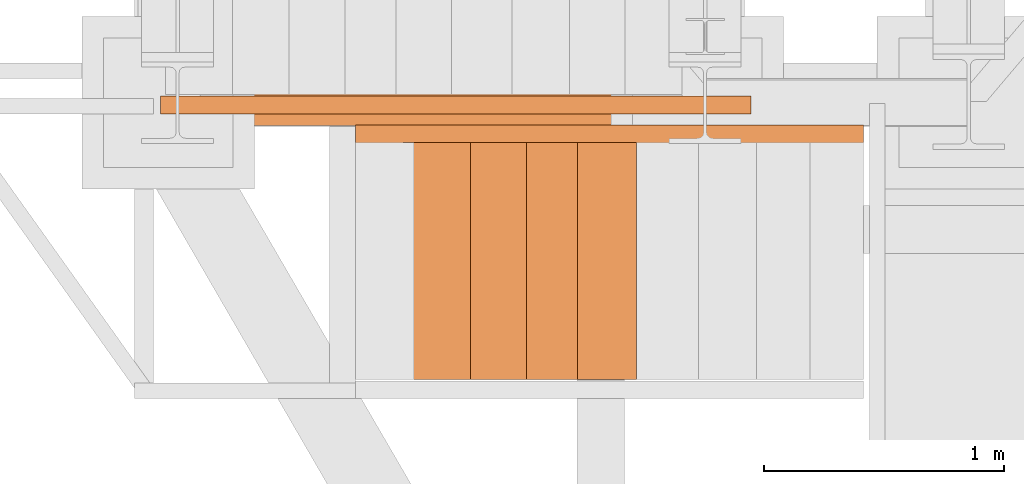
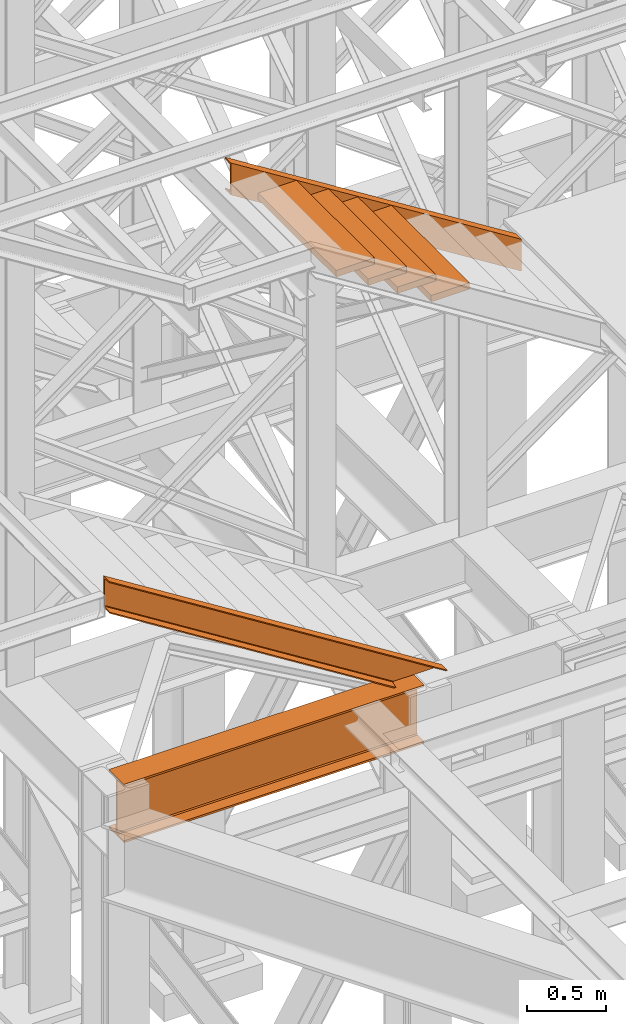
# One storey, part 21 of 208: 7 proxies.
"""IFC2X3 building model written with IfcOpenShell, lengths in millimetres."""

import ifcopenshell
import ifcopenshell.guid

model = None  # the IFC model being written
_history = None  # IfcOwnerHistory: only IFC2X3 demands one
_inside = {}  # id of a spatial element -> (the spatial element, [elements in it])
_under = {}  # id of a project, library or spatial element -> (it, [spatial elements below it])
_declared = {}  # id of a project -> (the project, [libraries it declares])
_typed = {}  # id of a type object -> (the type object, [elements of that type])
_made_of = {}  # id of a material, layer set ... -> (it, [elements and type objects made of it])


def new_model(schema):
    """Start an empty IFC model of exactly this schema.

    Asked for "IFC4X3", IfcOpenShell would pick the latest addendum, in which some entities
    have other attributes; the version numbers below select the first issue.
    IFC2X3 requires an IfcOwnerHistory on every rooted entity: one is made here for all.
    """
    global model, _history
    if schema == "IFC4X3":
        model = ifcopenshell.file(schema_version=(4, 3, 0, 0))
    else:
        model = ifcopenshell.file(schema=schema)
    _inside.clear()
    _under.clear()
    _declared.clear()
    _typed.clear()
    _made_of.clear()
    _history = None
    if model.schema == "IFC2X3":
        org = make("IfcOrganization", Name="unknown")
        user = make(
            "IfcPersonAndOrganization",
            ThePerson=make("IfcPerson", FamilyName="unknown"),
            TheOrganization=org,
        )
        app = make(
            "IfcApplication",
            ApplicationDeveloper=org,
            Version="unknown",
            ApplicationFullName="unknown",
            ApplicationIdentifier="unknown",
        )
        _history = make(
            "IfcOwnerHistory",
            OwningUser=user,
            OwningApplication=app,
            ChangeAction="ADDED",
            CreationDate=0,
        )
    return model


def make(cls, **values):
    """One entity of the class cls with the attributes given. An attribute that is None is left unset."""
    return model.create_entity(
        cls, **{name: value for name, value in values.items() if value is not None}
    )


def entity(cls, *values):
    """Any entity or typed value of the class cls, its attributes in the order of the schema. None: left unset."""
    e = model.create_entity(cls)
    for i, value in enumerate(values):
        if value is not None:
            e[i] = value
    return e


def rooted(cls, **values):
    """An entity with a GlobalId (a new one), such as an element, a storey or a relation."""
    return make(cls, GlobalId=ifcopenshell.guid.new(), OwnerHistory=_history, **values)


def si_unit(unit_type, name, prefix=None):
    """IfcSIUnit, for example si_unit("LENGTHUNIT", "METRE", prefix="MILLI")."""
    return make("IfcSIUnit", UnitType=unit_type, Prefix=prefix, Name=name)


def converted_unit(unit_type, name, factor, base, dimensions=None, offset=None):
    """IfcConversionBasedUnit, such as the inch: factor (a typed value) times the base unit."""
    return make(
        "IfcConversionBasedUnit"
        if offset is None
        else "IfcConversionBasedUnitWithOffset",
        ConversionOffset=offset,
        Dimensions=None
        if dimensions is None
        else entity("IfcDimensionalExponents", *dimensions),
        UnitType=unit_type,
        Name=name,
        ConversionFactor=make(
            "IfcMeasureWithUnit", ValueComponent=factor, UnitComponent=base
        ),
    )


def assignment(units):
    """IfcUnitAssignment: the units of a project."""
    return None if units is None else make("IfcUnitAssignment", Units=units)


def point(xyz):
    """IfcCartesianPoint."""
    return None if xyz is None else make("IfcCartesianPoint", Coordinates=xyz)


def direction(xyz):
    """IfcDirection."""
    return None if xyz is None else make("IfcDirection", DirectionRatios=xyz)


def frame(location, z_axis=None, x_axis=None):
    """IfcAxis2Placement3D, a coordinate frame: its origin and axes. An axis left out is left unset."""
    return make(
        "IfcAxis2Placement3D",
        Location=point(location),
        Axis=direction(z_axis),
        RefDirection=direction(x_axis),
    )


def origin():
    """The frame at (0, 0, 0) with its axes left unset."""
    return frame((0.0, 0.0, 0.0))


def origin_with_axes():
    """The frame at (0, 0, 0) with the z axis (0, 0, 1) and the x axis (1, 0, 0) written out."""
    return frame((0.0, 0.0, 0.0), z_axis=(0.0, 0.0, 1.0), x_axis=(1.0, 0.0, 0.0))


def place(relative_to, where):
    """IfcLocalPlacement: puts the frame where relative to a parent placement (None: the world)."""
    return make(
        "IfcLocalPlacement", PlacementRelTo=relative_to, RelativePlacement=where
    )


def context(
    kind, dimensions, precision=None, world=None, true_north=None, identifier=None
):
    """IfcGeometricRepresentationContext, for example the 3D "Model" context."""
    return make(
        "IfcGeometricRepresentationContext",
        ContextIdentifier=identifier,
        ContextType=kind,
        CoordinateSpaceDimension=dimensions,
        Precision=precision,
        WorldCoordinateSystem=world,
        TrueNorth=true_north,
    )


def subcontext(parent, identifier, kind, view, scale=None):
    """IfcGeometricRepresentationSubContext, for example "Body" below "Model"."""
    return make(
        "IfcGeometricRepresentationSubContext",
        ContextIdentifier=identifier,
        ContextType=kind,
        ParentContext=parent,
        TargetScale=scale,
        TargetView=view,
    )


def project(units=None, contexts=None):
    """IfcProject with its units and contexts."""
    return rooted(
        "IfcProject",
        Name="project",
        RepresentationContexts=contexts,
        UnitsInContext=assignment(units),
    )


def spatial(cls, under=None, at=None, **own):
    """A site, building, storey or space (cls), placed at a placement, below another one or the project."""
    s = rooted(cls, ObjectPlacement=at, **own)
    if under is not None:
        _under.setdefault(under.id(), (under, []))[1].append(s)
    return s


def faces_of(points, faces, orient=None, outer=None):
    """IfcFace entities. A face is a list of loops; a loop is a list of indices into points, from 0.

    orient and outer hold one flag for each loop. By default every Orientation is true, the
    first loop of a face is its IfcFaceOuterBound and the others are IfcFaceBound.
    """
    made = []
    for i, loops in enumerate(faces):
        bounds = []
        for j, loop in enumerate(loops):
            is_outer = j == 0 if outer is None else outer[i][j]
            bounds.append(
                make(
                    "IfcFaceOuterBound" if is_outer else "IfcFaceBound",
                    Bound=make("IfcPolyLoop", Polygon=[points[k] for k in loop]),
                    Orientation=True if orient is None else orient[i][j],
                )
            )
        made.append(make("IfcFace", Bounds=bounds))
    return made


def faceted_brep(points, faces, orient=None, outer=None, voids=None):
    """IfcFacetedBrep: a solid bounded by flat faces; with voids (closed shells), ...WithVoids."""
    shared = [point(p) for p in points]
    hull = make("IfcClosedShell", CfsFaces=faces_of(shared, faces, orient, outer))
    if voids is None:
        return make("IfcFacetedBrep", Outer=hull)
    return make(
        "IfcFacetedBrepWithVoids",
        Outer=hull,
        Voids=[
            make(cls, CfsFaces=faces_of(shared, fs, o, b)) for cls, fs, o, b in voids
        ],
    )


def shape(context_of_items, identifier, shape_type, items):
    """IfcShapeRepresentation: the items that make up one representation, for example the "Body"."""
    return make(
        "IfcShapeRepresentation",
        ContextOfItems=context_of_items,
        RepresentationIdentifier=identifier,
        RepresentationType=shape_type,
        Items=items,
    )


def made_of(thing, what):
    """Note that an element or type object is made of a material, layer set ...; save() writes the relation."""
    if what is not None:
        _made_of.setdefault(what.id(), (what, []))[1].append(thing)
    return thing


def element(
    cls,
    number,
    at=None,
    inside=None,
    cuts=None,
    type_object=None,
    material=None,
    context=None,
    identifier="Body",
    shape_type=None,
    held_by="IfcProductDefinitionShape",
    body=None,
    shapes=None,
    **own,
):
    """One element of the class cls, such as IfcWall. Its Tag is "e" and its number.

    at: its placement. inside: the storey or other place that contains it. cuts: it is an
    opening in that element (IfcRelVoidsElement). A single representation is given by context,
    identifier, shape_type and body (its items); several are given by shapes. held_by: the class
    of the entity that holds the representations. save() writes the other relations.
    """
    e = rooted(cls, Tag="e%d" % number, ObjectPlacement=at, **own)
    if body is not None:
        shapes = [shape(context, identifier, shape_type, body)]
    if shapes is not None:
        e.Representation = make(held_by, Representations=shapes)
    if inside is not None:
        _inside.setdefault(inside.id(), (inside, []))[1].append(e)
    if cuts is not None:
        rooted(
            "IfcRelVoidsElement", RelatingBuildingElement=cuts, RelatedOpeningElement=e
        )
    if type_object is not None:
        _typed.setdefault(type_object.id(), (type_object, []))[1].append(e)
    return made_of(e, material)


def aggregate(whole, parts):
    """IfcRelAggregates: a whole, such as a stair, and the parts it consists of."""
    return rooted("IfcRelAggregates", RelatingObject=whole, RelatedObjects=parts)


def save(model, path):
    """Write the relations noted so far, then the file.

    IfcRelAggregates (storeys below a building ...), IfcRelContainedInSpatialStructure (elements
    in a storey), IfcRelDefinesByType, IfcRelAssociatesMaterial and IfcRelDeclares: one each for
    every whole, place, type object, material and project.
    """
    for whole, parts in _under.values():
        aggregate(whole, parts)
    for where, things in _inside.values():
        rooted(
            "IfcRelContainedInSpatialStructure",
            RelatedElements=things,
            RelatingStructure=where,
        )
    for kind, things in _typed.values():
        rooted("IfcRelDefinesByType", RelatedObjects=things, RelatingType=kind)
    for what, things in _made_of.values():
        rooted("IfcRelAssociatesMaterial", RelatedObjects=things, RelatingMaterial=what)
    for by, libraries in _declared.values():
        rooted("IfcRelDeclares", RelatingContext=by, RelatedDefinitions=libraries)
    model.write(path)


model = new_model("IFC2X3")

# Units and contexts
model_context = context("Model", 3, precision=1e-05, world=origin())
plan_context = context("Plan", 3, precision=1e-05, world=origin())
body_context = subcontext(model_context, "Body", "Model", "MODEL_VIEW")
ifc_project = project(units=[si_unit("LENGTHUNIT", "METRE", prefix="MILLI"), converted_unit("PLANEANGLEUNIT", "DEGREE", entity("IfcPlaneAngleMeasure", 0.0174532925199433), si_unit("PLANEANGLEUNIT", "RADIAN"), dimensions=[0, 0, 0, 0, 0, 0, 0]), si_unit("AREAUNIT", "SQUARE_METRE"), si_unit("VOLUMEUNIT", "CUBIC_METRE")], contexts=[model_context, plan_context])

# Building, storey
building_placement = place(None, origin())
building = spatial("IfcBuilding", under=ifc_project, at=building_placement, CompositionType="COMPLEX")
storey_placement = place(building_placement, origin_with_axes())
storey = spatial("IfcBuildingStorey", under=building, at=storey_placement, Name="Geschoss", CompositionType="ELEMENT")

# Proxies
proxy_1_placement = place(storey_placement, frame((-3300.745031419179, -17357.574399786, 4834.989987483023), z_axis=(0.0, 0.0, 1.0), x_axis=(1.0, 0.0, 0.0)))
element("IfcBuildingElementProxy", 1, at=proxy_1_placement, inside=storey, context=body_context, shape_type="Brep", body=[
    faceted_brep([(2188.009999895692, 0.00999999999839929, 450.0100178813937), (2188.009999895692, 190.0100125169738, 450.0100178813937), (2188.009999895692, 190.0100125169738, 435.4100240564349), (2188.009999895692, 120.7100073045476, 435.4100091552737), (2188.009999895692, 109.8415622657522, 433.2347078418734), (2188.009999895692, 101.8853126263603, 425.2784563398363), (2188.009999895692, 99.71000619068582, 414.4100113010409), (2188.009999895692, 99.71000619068582, 35.60999167919181), (2188.009999895692, 101.8853126263603, 24.74154664039634), (2188.009999895692, 109.8415622657522, 16.78529513835929), (2188.009999895692, 120.7100073045476, 14.60999382495902), (2188.009999895692, 190.0100125169738, 14.60999382495902), (2188.009999895692, 190.0100125169738, 0.01000000000021828), (2188.009999895692, 0.00999999999839929, 0.01000000000021828), (2188.009999895692, 0.00999999999839929, 14.60999382495902), (2188.009999895692, 69.31000521242458, 14.60999382495902), (2188.009999895692, 80.17845025122006, 16.78529513835929), (2188.009999895692, 88.13469989061196, 24.74154664039634), (2188.009999895692, 90.31000632628638, 35.60999167919181), (2188.009999895692, 90.31000632628638, 414.4100113010409), (2188.009999895692, 88.13469989061196, 425.2784563398363), (2188.009999895692, 80.17845025122006, 433.2347078418734), (2188.009999895692, 69.31000521242458, 435.4100091552737), (2188.009999895692, 0.00999999999839929, 435.4100240564349), (2188.009999895692, 190.0100125169738, 450.0100178813937), (2188.009999895692, 0.00999999999839929, 450.0100178813937), (0.01000000000021828, 0.00999999999839929, 450.0100178813937), (0.01000000000021828, 190.0100125169738, 450.0100178813937), (2188.009999895692, 190.0100125169738, 435.4100240564349), (2188.009999895692, 190.0100125169738, 450.0100178813937), (0.01000000000021828, 190.0100125169738, 450.0100178813937), (0.01000000000021828, 190.0100125169738, 435.4100240564349), (2188.009999895692, 120.7100073045476, 435.4100091552737), (2188.009999895692, 190.0100125169738, 435.4100240564349), (0.01000000000021828, 190.0100125169738, 435.4100240564349), (0.01000000000021828, 120.7100073045476, 435.4100091552737), (2188.009999895692, 109.8415622657522, 433.2347078418734), (2188.009999895692, 120.7100073045476, 435.4100091552737), (0.01000000000021828, 120.7100073045476, 435.4100091552737), (0.01000000000021828, 109.8415622657522, 433.2347078418734), (2188.009999895692, 101.8853126263603, 425.2784563398363), (2188.009999895692, 109.8415622657522, 433.2347078418734), (0.01000000000021828, 109.8415622657522, 433.2347078418734), (0.01000000000021828, 101.8853126263603, 425.2784563398363), (2188.009999895692, 99.71000619068582, 414.4100113010409), (2188.009999895692, 101.8853126263603, 425.2784563398363), (0.01000000000021828, 101.8853126263603, 425.2784563398363), (0.01000000000021828, 99.71000619068582, 414.4100113010409), (2188.009999895692, 99.71000619068582, 35.60999167919181), (2188.009999895692, 99.71000619068582, 414.4100113010409), (0.01000000000021828, 99.71000619068582, 414.4100113010409), (0.01000000000021828, 99.71000619068582, 35.60999167919181), (2188.009999895692, 101.8853126263603, 24.74154664039634), (2188.009999895692, 99.71000619068582, 35.60999167919181), (0.01000000000021828, 99.71000619068582, 35.60999167919181), (0.01000000000021828, 101.8853126263603, 24.74154664039634), (2188.009999895692, 109.8415622657522, 16.78529513835929), (2188.009999895692, 101.8853126263603, 24.74154664039634), (0.01000000000021828, 101.8853126263603, 24.74154664039634), (0.01000000000021828, 109.8415622657522, 16.78529513835929), (2188.009999895692, 120.7100073045476, 14.60999382495902), (2188.009999895692, 109.8415622657522, 16.78529513835929), (0.01000000000021828, 109.8415622657522, 16.78529513835929), (0.01000000000021828, 120.7100073045476, 14.60999382495902), (2188.009999895692, 190.0100125169738, 14.60999382495902), (2188.009999895692, 120.7100073045476, 14.60999382495902), (0.01000000000021828, 120.7100073045476, 14.60999382495902), (0.01000000000021828, 190.0100125169738, 14.60999382495902), (2188.009999895692, 190.0100125169738, 0.01000000000021828), (2188.009999895692, 190.0100125169738, 14.60999382495902), (0.01000000000021828, 190.0100125169738, 14.60999382495902), (0.01000000000021828, 190.0100125169738, 0.01000000000021828), (2188.009999895692, 0.00999999999839929, 0.01000000000021828), (2188.009999895692, 190.0100125169738, 0.01000000000021828), (0.01000000000021828, 190.0100125169738, 0.01000000000021828), (0.01000000000021828, 0.00999999999839929, 0.01000000000021828), (2188.009999895692, 0.00999999999839929, 14.60999382495902), (2188.009999895692, 0.00999999999839929, 0.01000000000021828), (0.01000000000021828, 0.00999999999839929, 0.01000000000021828), (0.01000000000021828, 0.00999999999839929, 14.60999382495902), (2188.009999895692, 69.31000521242458, 14.60999382495902), (2188.009999895692, 0.00999999999839929, 14.60999382495902), (0.01000000000021828, 0.00999999999839929, 14.60999382495902), (0.01000000000021828, 69.31000521242458, 14.60999382495902), (2188.009999895692, 80.17845025122006, 16.78529513835929), (2188.009999895692, 69.31000521242458, 14.60999382495902), (0.01000000000021828, 69.31000521242458, 14.60999382495902), (0.01000000000021828, 80.17845025122006, 16.78529513835929), (2188.009999895692, 88.13469989061196, 24.74154664039634), (2188.009999895692, 80.17845025122006, 16.78529513835929), (0.01000000000021828, 80.17845025122006, 16.78529513835929), (0.01000000000021828, 88.13469989061196, 24.74154664039634), (2188.009999895692, 90.31000632628638, 35.60999167919181), (2188.009999895692, 88.13469989061196, 24.74154664039634), (0.01000000000021828, 88.13469989061196, 24.74154664039634), (0.01000000000021828, 90.31000632628638, 35.60999167919181), (2188.009999895692, 90.31000632628638, 414.4100113010409), (2188.009999895692, 90.31000632628638, 35.60999167919181), (0.01000000000021828, 90.31000632628638, 35.60999167919181), (0.01000000000021828, 90.31000632628638, 414.4100113010409), (2188.009999895692, 88.13469989061196, 425.2784563398363), (2188.009999895692, 90.31000632628638, 414.4100113010409), (0.01000000000021828, 90.31000632628638, 414.4100113010409), (0.01000000000021828, 88.13469989061196, 425.2784563398363), (2188.009999895692, 80.17845025122006, 433.2347078418734), (2188.009999895692, 88.13469989061196, 425.2784563398363), (0.01000000000021828, 88.13469989061196, 425.2784563398363), (0.01000000000021828, 80.17845025122006, 433.2347078418734), (2188.009999895692, 69.31000521242458, 435.4100091552737), (2188.009999895692, 80.17845025122006, 433.2347078418734), (0.01000000000021828, 80.17845025122006, 433.2347078418734), (0.01000000000021828, 69.31000521242458, 435.4100091552737), (2188.009999895692, 0.00999999999839929, 435.4100240564349), (2188.009999895692, 69.31000521242458, 435.4100091552737), (0.01000000000021828, 69.31000521242458, 435.4100091552737), (0.01000000000021828, 0.00999999999839929, 435.4100240564349), (2188.009999895692, 0.00999999999839929, 450.0100178813937), (2188.009999895692, 0.00999999999839929, 435.4100240564349), (0.01000000000021828, 0.00999999999839929, 435.4100240564349), (0.01000000000021828, 0.00999999999839929, 450.0100178813937), (0.01000000000021828, 0.00999999999839929, 450.0100178813937), (0.01000000000021828, 0.00999999999839929, 435.4100240564349), (0.01000000000021828, 69.31000521242458, 435.4100091552737), (0.01000000000021828, 80.17845025122006, 433.2347078418734), (0.01000000000021828, 88.13469989061196, 425.2784563398363), (0.01000000000021828, 90.31000632628638, 414.4100113010409), (0.01000000000021828, 90.31000632628638, 35.60999167919181), (0.01000000000021828, 88.13469989061196, 24.74154664039634), (0.01000000000021828, 80.17845025122006, 16.78529513835929), (0.01000000000021828, 69.31000521242458, 14.60999382495902), (0.01000000000021828, 0.00999999999839929, 14.60999382495902), (0.01000000000021828, 0.00999999999839929, 0.01000000000021828), (0.01000000000021828, 190.0100125169738, 0.01000000000021828), (0.01000000000021828, 190.0100125169738, 14.60999382495902), (0.01000000000021828, 120.7100073045476, 14.60999382495902), (0.01000000000021828, 109.8415622657522, 16.78529513835929), (0.01000000000021828, 101.8853126263603, 24.74154664039634), (0.01000000000021828, 99.71000619068582, 35.60999167919181), (0.01000000000021828, 99.71000619068582, 414.4100113010409), (0.01000000000021828, 101.8853126263603, 425.2784563398363), (0.01000000000021828, 109.8415622657522, 433.2347078418734), (0.01000000000021828, 120.7100073045476, 435.4100091552737), (0.01000000000021828, 190.0100125169738, 435.4100240564349), (0.01000000000021828, 190.0100125169738, 450.0100178813937)], [[[0, 1, 2, 3, 4, 5, 6, 7, 8, 9, 10, 11, 12, 13, 14, 15, 16, 17, 18, 19, 20, 21, 22, 23]], [[24, 25, 26, 27]], [[28, 29, 30, 31]], [[32, 33, 34, 35]], [[36, 37, 38, 39]], [[40, 41, 42, 43]], [[44, 45, 46, 47]], [[48, 49, 50, 51]], [[52, 53, 54, 55]], [[56, 57, 58, 59]], [[60, 61, 62, 63]], [[64, 65, 66, 67]], [[68, 69, 70, 71]], [[72, 73, 74, 75]], [[76, 77, 78, 79]], [[80, 81, 82, 83]], [[84, 85, 86, 87]], [[88, 89, 90, 91]], [[92, 93, 94, 95]], [[96, 97, 98, 99]], [[100, 101, 102, 103]], [[104, 105, 106, 107]], [[108, 109, 110, 111]], [[112, 113, 114, 115]], [[116, 117, 118, 119]], [[120, 121, 122, 123, 124, 125, 126, 127, 128, 129, 130, 131, 132, 133, 134, 135, 136, 137, 138, 139, 140, 141, 142, 143]]], orient=[[False], [False], [False], [False], [False], [False], [False], [False], [False], [False], [False], [False], [False], [False], [False], [False], [False], [False], [False], [False], [False], [False], [False], [False], [False], [False]]),
])
for number, where, z_axis, x_axis in (
    (2, (-1673.666828882966, -18416.66561009758, 9075.185220743773), (0.0, 0.0, 1.0), (1.0, 0.0, 0.0)),
    (3, (-1919.160184020018, -18416.66561009758, 9225.654269958271), (0.0, 0.0, 1.0), (1.0, 0.0, 0.0)),
):
    element("IfcBuildingElementProxy", number, at=place(storey_placement, frame(where, z_axis=z_axis, x_axis=x_axis)), inside=storey, context=body_context, shape_type="Brep", body=[
        faceted_brep([(0.009999999999990905, 0.00999999999839929, 0.01000000000021828), (280.2746556316176, 0.00999999999839929, 0.01000000000021828), (280.2746556316176, 988.9080206708568, 0.01000000000021828), (0.009999999999990905, 988.9080206708568, 0.01000000000021828), (280.2746556316176, 0.00999999999839929, 50.01000000000022), (0.009999999999990905, 0.00999999999839929, 50.01000000000022), (0.009999999999990905, 988.9080206708568, 50.01000000000022), (280.2746556316176, 988.9080206708568, 50.01000000000022), (280.2746556316176, 0.00999999999839929, 0.01000000000021828), (0.009999999999990905, 0.00999999999839929, 0.01000000000021828), (0.009999999999990905, 0.00999999999839929, 50.01000000000022), (280.2746556316176, 0.00999999999839929, 50.01000000000022), (280.2746556316176, 988.9080206708568, 0.01000000000021828), (280.2746556316176, 0.00999999999839929, 0.01000000000021828), (280.2746556316176, 0.00999999999839929, 50.01000000000022), (280.2746556316176, 988.9080206708568, 50.01000000000022), (0.009999999999990905, 988.9080206708568, 0.01000000000021828), (280.2746556316176, 988.9080206708568, 0.01000000000021828), (280.2746556316176, 988.9080206708568, 50.01000000000022), (0.009999999999990905, 988.9080206708568, 50.01000000000022), (0.009999999999990905, 0.00999999999839929, 0.01000000000021828), (0.009999999999990905, 988.9080206708568, 0.01000000000021828), (0.009999999999990905, 988.9080206708568, 50.01000000000022), (0.009999999999990905, 0.00999999999839929, 50.01000000000022)], [[[0, 1, 2, 3]], [[4, 5, 6, 7]], [[8, 9, 10, 11]], [[12, 13, 14, 15]], [[16, 17, 18, 19]], [[20, 21, 22, 23]]], orient=[[False], [False], [False], [False], [False], [False]]),
    ])
for number, where, z_axis, x_axis in (
    (4, (-2131.657047224922, -18416.66561009758, 9362.681031777307), (0.0, 0.0, 1.0), (1.0, 0.0, 0.0)),
    (5, (-2365.92170285654, -18416.66561009758, 9509.736808232814), (0.0, 0.0, 1.0), (1.0, 0.0, 0.0)),
):
    element("IfcBuildingElementProxy", number, at=place(storey_placement, frame(where, z_axis=z_axis, x_axis=x_axis)), inside=storey, context=body_context, shape_type="Brep", body=[
        faceted_brep([(0.01000000000021828, 0.00999999999839929, 0.01000000000021828), (280.2746556316179, 0.00999999999839929, 0.01000000000021828), (280.2746556316179, 988.9080206708568, 0.01000000000021828), (0.01000000000021828, 988.9080206708568, 0.01000000000021828), (280.2746556316179, 0.00999999999839929, 50.01000000000022), (0.01000000000021828, 0.00999999999839929, 50.01000000000022), (0.01000000000021828, 988.9080206708568, 50.01000000000022), (280.2746556316179, 988.9080206708568, 50.01000000000022), (280.2746556316179, 0.00999999999839929, 0.01000000000021828), (0.01000000000021828, 0.00999999999839929, 0.01000000000021828), (0.01000000000021828, 0.00999999999839929, 50.01000000000022), (280.2746556316179, 0.00999999999839929, 50.01000000000022), (280.2746556316179, 988.9080206708568, 0.01000000000021828), (280.2746556316179, 0.00999999999839929, 0.01000000000021828), (280.2746556316179, 0.00999999999839929, 50.01000000000022), (280.2746556316179, 988.9080206708568, 50.01000000000022), (0.01000000000021828, 988.9080206708568, 0.01000000000021828), (280.2746556316179, 988.9080206708568, 0.01000000000021828), (280.2746556316179, 988.9080206708568, 50.01000000000022), (0.01000000000021828, 988.9080206708568, 50.01000000000022), (0.01000000000021828, 0.00999999999839929, 0.01000000000021828), (0.01000000000021828, 988.9080206708568, 0.01000000000021828), (0.01000000000021828, 988.9080206708568, 50.01000000000022), (0.01000000000021828, 0.00999999999839929, 50.01000000000022)], [[[0, 1, 2, 3]], [[4, 5, 6, 7]], [[8, 9, 10, 11]], [[12, 13, 14, 15]], [[16, 17, 18, 19]], [[20, 21, 22, 23]]], orient=[[False], [False], [False], [False], [False], [False]]),
    ])
proxy_2_placement = place(storey_placement, frame((-2563.970189809399, -17431.67642242955, 8284.990002086157), z_axis=(0.0, 0.0, 1.0), x_axis=(1.0, 0.0, 0.0)))
element("IfcBuildingElementProxy", 6, at=proxy_2_placement, inside=storey, context=body_context, shape_type="Brep", body=[
    faceted_brep([(0.01000000000021828, 0.00999999999839929, 1329.446611849271), (0.01000000000021828, 0.00999999999839929, 1575.009997913843), (2117.845950178831, 0.00999999999839929, 245.5733860645723), (2117.845950178831, 0.00999999999839929, 0.01000000000021828), (0.01000000000021828, 0.00999999999839929, 1575.009997913843), (0.01000000000021828, 75.01000111758549, 1575.009997913843), (2117.845950178831, 75.01000111758549, 245.5733860645723), (2117.845950178831, 0.00999999999839929, 245.5733860645723), (0.01000000000021828, 75.01000111758549, 1575.009997913843), (0.01000000000021828, 75.01000111758549, 1571.37463962815), (2117.845950178831, 75.01000111758549, 241.9380277788805), (2117.845950178831, 75.01000111758549, 245.5733860645723), (0.01000000000021828, 75.01000111758549, 1571.37463962815), (0.01000000000021828, 73.89400100171406, 1565.9746968948), (2117.845950178831, 73.89400100171406, 236.5380850455294), (2117.845950178831, 75.01000111758549, 241.9380277788805), (0.01000000000021828, 73.89400100171406, 1565.9746968948), (0.01000000000021828, 69.488472694753, 1564.031196863314), (2117.845950178831, 69.488472694753, 234.5945850140433), (2117.845950178831, 73.89400100171406, 236.5380850455294), (0.01000000000021828, 69.488472694753, 1564.031196863314), (0.01000000000021828, 19.09293180167515, 1559.081077071371), (2117.845950178831, 19.09293180167515, 229.6444652221016), (2117.845950178831, 69.488472694753, 234.5945850140433), (0.01000000000021828, 19.09293180167515, 1559.081077071371), (0.01000000000021828, 13.35380079060633, 1557.122437184522), (2117.845950178831, 13.35380079060633, 227.6858253352511), (2117.845950178831, 19.09293180167515, 229.6444652221016), (0.01000000000021828, 13.35380079060633, 1557.122437184522), (0.01000000000021828, 9.500150026975462, 1551.867013747282), (2117.845950178831, 9.500150026975462, 222.430401898011), (2117.845950178831, 13.35380079060633, 227.6858253352511), (0.01000000000021828, 9.500150026975462, 1551.867013747282), (0.01000000000021828, 8.510000461934396, 1545.006152728727), (2117.845950178831, 8.510000461934396, 215.5695408794563), (2117.845950178831, 9.500150026975462, 222.430401898011), (0.01000000000021828, 8.510000461934396, 1545.006152728727), (0.01000000000021828, 8.510000461934396, 1359.450457034389), (2117.845950178831, 8.510000461934396, 30.01384518511804), (2117.845950178831, 8.510000461934396, 215.5695408794563), (0.01000000000021828, 8.510000461934396, 1359.450457034389), (0.01000000000021828, 9.500150026975462, 1352.589596015832), (2117.845950178831, 9.500150026975462, 23.15298416656151), (2117.845950178831, 8.510000461934396, 30.01384518511804), (0.01000000000021828, 9.500150026975462, 1352.589596015832), (0.01000000000021828, 13.35380079060633, 1347.334172578592), (2117.845950178831, 13.35380079060633, 17.89756072932141), (2117.845950178831, 9.500150026975462, 23.15298416656151), (0.01000000000021828, 13.35380079060633, 1347.334172578592), (0.01000000000021828, 19.09293180167515, 1345.375532691742), (2117.845950178831, 19.09293180167515, 15.93892084247273), (2117.845950178831, 13.35380079060633, 17.89756072932141), (0.01000000000021828, 19.09293180167515, 1345.375532691742), (0.01000000000021828, 69.488472694753, 1340.425412899804), (2117.845950178831, 69.488472694753, 10.98880105053104), (2117.845950178831, 19.09293180167515, 15.93892084247273), (0.01000000000021828, 69.488472694753, 1340.425412899804), (0.01000000000021828, 73.89400100171406, 1338.481912868316), (2117.845950178831, 73.89400100171406, 9.045301019044928), (2117.845950178831, 69.488472694753, 10.98880105053104), (0.01000000000021828, 73.89400100171406, 1338.481912868316), (0.01000000000021828, 75.01000111758549, 1333.081970134965), (2117.845950178831, 75.01000111758549, 3.645358285693874), (2117.845950178831, 73.89400100171406, 9.045301019044928), (0.01000000000021828, 75.01000111758549, 1333.081970134965), (0.01000000000021828, 75.01000111758549, 1329.446611849271), (2117.845950178831, 75.01000111758549, 0.01000000000021828), (2117.845950178831, 75.01000111758549, 3.645358285693874), (0.01000000000021828, 75.01000111758549, 1329.446611849271), (0.01000000000021828, 0.00999999999839929, 1329.446611849271), (2117.845950178831, 0.00999999999839929, 0.01000000000021828), (2117.845950178831, 75.01000111758549, 0.01000000000021828), (2117.845950178831, 0.00999999999839929, 0.01000000000021828), (2117.845950178831, 0.00999999999839929, 245.5733860645723), (2117.845950178831, 75.01000111758549, 245.5733860645723), (2117.845950178831, 75.01000111758549, 241.9380277788805), (2117.845950178831, 73.89400100171406, 236.5380850455294), (2117.845950178831, 69.488472694753, 234.5945850140433), (2117.845950178831, 19.09293180167515, 229.6444652221016), (2117.845950178831, 13.35380079060633, 227.6858253352511), (2117.845950178831, 9.500150026975462, 222.430401898011), (2117.845950178831, 8.510000461934396, 215.5695408794563), (2117.845950178831, 8.510000461934396, 30.01384518511804), (2117.845950178831, 9.500150026975462, 23.15298416656151), (2117.845950178831, 13.35380079060633, 17.89756072932141), (2117.845950178831, 19.09293180167515, 15.93892084247273), (2117.845950178831, 69.488472694753, 10.98880105053104), (2117.845950178831, 73.89400100171406, 9.045301019044928), (2117.845950178831, 75.01000111758549, 3.645358285693874), (2117.845950178831, 75.01000111758549, 0.01000000000021828), (0.01000000000021828, 0.00999999999839929, 1329.446611849271), (0.01000000000021828, 75.01000111758549, 1329.446611849271), (0.01000000000021828, 75.01000111758549, 1333.081970134965), (0.01000000000021828, 73.89400100171406, 1338.481912868316), (0.01000000000021828, 69.488472694753, 1340.425412899804), (0.01000000000021828, 19.09293180167515, 1345.375532691742), (0.01000000000021828, 13.35380079060633, 1347.334172578592), (0.01000000000021828, 9.500150026975462, 1352.589596015832), (0.01000000000021828, 8.510000461934396, 1359.450457034389), (0.01000000000021828, 8.510000461934396, 1545.006152728727), (0.01000000000021828, 9.500150026975462, 1551.867013747282), (0.01000000000021828, 13.35380079060633, 1557.122437184522), (0.01000000000021828, 19.09293180167515, 1559.081077071371), (0.01000000000021828, 69.488472694753, 1564.031196863314), (0.01000000000021828, 73.89400100171406, 1565.9746968948), (0.01000000000021828, 75.01000111758549, 1571.37463962815), (0.01000000000021828, 75.01000111758549, 1575.009997913843), (0.01000000000021828, 0.00999999999839929, 1575.009997913843)], [[[0, 1, 2, 3]], [[4, 5, 6, 7]], [[8, 9, 10, 11]], [[12, 13, 14, 15]], [[16, 17, 18, 19]], [[20, 21, 22, 23]], [[24, 25, 26, 27]], [[28, 29, 30, 31]], [[32, 33, 34, 35]], [[36, 37, 38, 39]], [[40, 41, 42, 43]], [[44, 45, 46, 47]], [[48, 49, 50, 51]], [[52, 53, 54, 55]], [[56, 57, 58, 59]], [[60, 61, 62, 63]], [[64, 65, 66, 67]], [[68, 69, 70, 71]], [[72, 73, 74, 75, 76, 77, 78, 79, 80, 81, 82, 83, 84, 85, 86, 87, 88, 89]], [[90, 91, 92, 93, 94, 95, 96, 97, 98, 99, 100, 101, 102, 103, 104, 105, 106, 107]]], orient=[[False], [False], [False], [False], [False], [False], [False], [False], [False], [False], [False], [False], [False], [False], [False], [False], [False], [False], [False], [False]]),
])
proxy_3_placement = place(storey_placement, frame((-3377.982231929546, -17309.46225064734, 5299.235995667717), z_axis=(0.0, 0.0, 1.0), x_axis=(1.0, 0.0, 0.0)))
element("IfcBuildingElementProxy", 7, at=proxy_3_placement, inside=storey, context=body_context, shape_type="Brep", body=[
    faceted_brep([(0.009999999999763531, 75.01000111758549, 1546.59864079531), (0.009999999999763531, 75.01000111758549, 1301.035254730738), (2072.585730200911, 75.01000111758549, 0.01000000000021828), (2463.776225798724, 75.01000111758549, 0.01000000000021828), (0.009999999999763531, 0.00999999999839929, 1546.59864079531), (0.009999999999763531, 75.01000111758549, 1546.59864079531), (2463.776225798724, 75.01000111758549, 0.01000000000021828), (2463.776225798724, 0.00999999999839929, 0.01000000000021828), (0.009999999999763531, 0.00999999999839929, 1542.963282509618), (0.009999999999763531, 0.00999999999839929, 1546.59864079531), (2463.776225798724, 0.00999999999839929, 0.01000000000021828), (2457.984981296655, 0.00999999999839929, 0.01000000000021828), (0.009999999999763531, 1.126000115869829, 1537.563339776265), (0.009999999999763531, 0.00999999999839929, 1542.963282509618), (2457.984981296655, 0.00999999999839929, 0.01000000000021828), (2449.382696127383, 1.126000115869829, 0.01000000000021828), (0.009999999999763531, 5.531528422830888, 1535.619839744779), (0.009999999999763531, 1.126000115869829, 1537.563339776265), (2449.382696127383, 1.126000115869829, 0.01000000000021828), (2446.28663709067, 5.531528422830888, 0.01000000000112777), (0.009999999999763531, 55.92706931590874, 1530.669719952837), (0.009999999999763531, 5.531528422830888, 1535.619839744779), (2446.28663709067, 5.531528422830888, 0.01000000000112777), (2438.400934561022, 55.92706931590874, 0.01000000000112777), (0.009999999999763531, 61.66620032697756, 1528.711080065987), (0.009999999999763531, 55.92706931590874, 1530.669719952837), (2438.400934561022, 55.92706931590874, 0.01000000000112777), (2435.280757240153, 61.66620032697756, 0.009999999999308784), (0.009999999999763531, 65.51985109060843, 1523.455656628748), (0.009999999999763531, 61.66620032697756, 1528.711080065987), (2435.280757240153, 61.66620032697756, 0.009999999999308784), (2426.908696030465, 65.51985109060843, 0.01000000000021828), (0.009999999999763531, 66.51000065564949, 1516.594795610194), (0.009999999999763531, 65.51985109060843, 1523.455656628748), (2426.908696030465, 65.51985109060843, 0.01000000000021828), (2415.979120310367, 66.51000065564949, 0.01000000000112777), (0.009999999999763531, 66.51000065564949, 1331.039099915855), (0.009999999999763531, 66.51000065564949, 1516.594795610194), (2415.979120310367, 66.51000065564949, 0.01000000000112777), (2120.382835689267, 66.51000065564949, 0.01000000000021828), (0.009999999999763531, 65.51985109060843, 1324.178238897299), (0.009999999999763531, 66.51000065564949, 1331.039099915855), (2120.382835689267, 66.51000065564949, 0.01000000000021828), (2109.453259969165, 65.51985109060843, 0.01000000000021828), (0.009999999999763531, 61.66620032697756, 1318.922815460059), (0.009999999999763531, 65.51985109060843, 1324.178238897299), (2109.453259969165, 65.51985109060843, 0.01000000000021828), (2101.081198759479, 61.66620032697756, 0.01000000000021828), (0.009999999999763531, 55.92706931590874, 1316.964175573208), (0.009999999999763531, 61.66620032697756, 1318.922815460059), (2101.081198759479, 61.66620032697756, 0.01000000000021828), (2097.961021438609, 55.92706931590874, 0.01000000000203727), (0.009999999999763531, 5.531528422830888, 1312.01405578127), (0.009999999999763531, 55.92706931590874, 1316.964175573208), (2097.961021438609, 55.92706931590874, 0.01000000000203727), (2090.075318908965, 5.531528422830888, 0.01000000000021828), (0.009999999999763531, 1.126000115869829, 1310.070555749782), (0.009999999999763531, 5.531528422830888, 1312.01405578127), (2090.075318908965, 5.531528422830888, 0.01000000000021828), (2086.979259872248, 1.126000115869829, 0.01000000000385626), (0.009999999999763531, 0.00999999999839929, 1304.670613016431), (0.009999999999763531, 1.126000115869829, 1310.070555749782), (2086.979259872248, 1.126000115869829, 0.01000000000385626), (2078.37697470298, 0.00999999999839929, 0.01000000000021828), (0.009999999999763531, 0.00999999999839929, 1301.035254730738), (0.009999999999763531, 0.00999999999839929, 1304.670613016431), (2078.37697470298, 0.00999999999839929, 0.01000000000021828), (2072.585730200911, 0.00999999999839929, 0.01000000000021828), (0.009999999999763531, 75.01000111758549, 1301.035254730738), (0.009999999999763531, 0.00999999999839929, 1301.035254730738), (2072.585730200911, 0.00999999999839929, 0.01000000000021828), (2072.585730200911, 75.01000111758549, 0.01000000000021828), (0.009999999999763531, 75.01000111758549, 1546.59864079531), (0.009999999999763531, 0.00999999999839929, 1546.59864079531), (0.009999999999763531, 0.00999999999839929, 1542.963282509618), (0.009999999999763531, 1.126000115869829, 1537.563339776265), (0.009999999999763531, 5.531528422830888, 1535.619839744779), (0.009999999999763531, 55.92706931590874, 1530.669719952837), (0.009999999999763531, 61.66620032697756, 1528.711080065987), (0.009999999999763531, 65.51985109060843, 1523.455656628748), (0.009999999999763531, 66.51000065564949, 1516.594795610194), (0.009999999999763531, 66.51000065564949, 1331.039099915855), (0.009999999999763531, 65.51985109060843, 1324.178238897299), (0.009999999999763531, 61.66620032697756, 1318.922815460059), (0.009999999999763531, 55.92706931590874, 1316.964175573208), (0.009999999999763531, 5.531528422830888, 1312.01405578127), (0.009999999999763531, 1.126000115869829, 1310.070555749782), (0.009999999999763531, 0.00999999999839929, 1304.670613016431), (0.009999999999763531, 0.00999999999839929, 1301.035254730738), (0.009999999999763531, 75.01000111758549, 1301.035254730738), (2463.776225798724, 75.01000111758549, 0.01000000000021828), (2072.585730200911, 75.01000111758549, 0.01000000000021828), (2072.585730200911, 0.00999999999839929, 0.01000000000021828), (2078.37697470298, 0.00999999999839929, 0.01000000000021828), (2086.979259872248, 1.126000115869829, 0.01000000000385626), (2090.075318908965, 5.531528422830888, 0.01000000000021828), (2097.961021438609, 55.92706931590874, 0.01000000000203727), (2101.081198759479, 61.66620032697756, 0.01000000000021828), (2109.453259969165, 65.51985109060843, 0.01000000000021828), (2120.382835689267, 66.51000065564949, 0.01000000000021828), (2415.979120310367, 66.51000065564949, 0.01000000000112777), (2426.908696030465, 65.51985109060843, 0.01000000000021828), (2435.280757240153, 61.66620032697756, 0.009999999999308784), (2438.400934561022, 55.92706931590874, 0.01000000000112777), (2446.28663709067, 5.531528422830888, 0.01000000000112777), (2449.382696127383, 1.126000115869829, 0.01000000000021828), (2457.984981296655, 0.00999999999839929, 0.01000000000021828), (2463.776225798724, 0.00999999999839929, 0.01000000000021828)], [[[0, 1, 2, 3]], [[4, 5, 6, 7]], [[8, 9, 10, 11]], [[12, 13, 14, 15]], [[16, 17, 18, 19]], [[20, 21, 22, 23]], [[24, 25, 26, 27]], [[28, 29, 30, 31]], [[32, 33, 34, 35]], [[36, 37, 38, 39]], [[40, 41, 42, 43]], [[44, 45, 46, 47]], [[48, 49, 50, 51]], [[52, 53, 54, 55]], [[56, 57, 58, 59]], [[60, 61, 62, 63]], [[64, 65, 66, 67]], [[68, 69, 70, 71]], [[72, 73, 74, 75, 76, 77, 78, 79, 80, 81, 82, 83, 84, 85, 86, 87, 88, 89]], [[90, 91, 92, 93, 94, 95, 96, 97, 98, 99, 100, 101, 102, 103, 104, 105, 106, 107]]], orient=[[False], [False], [False], [False], [False], [False], [False], [False], [False], [False], [False], [False], [False], [False], [False], [False], [False], [False], [False], [False]]),
])

save(model, "model.ifc")
